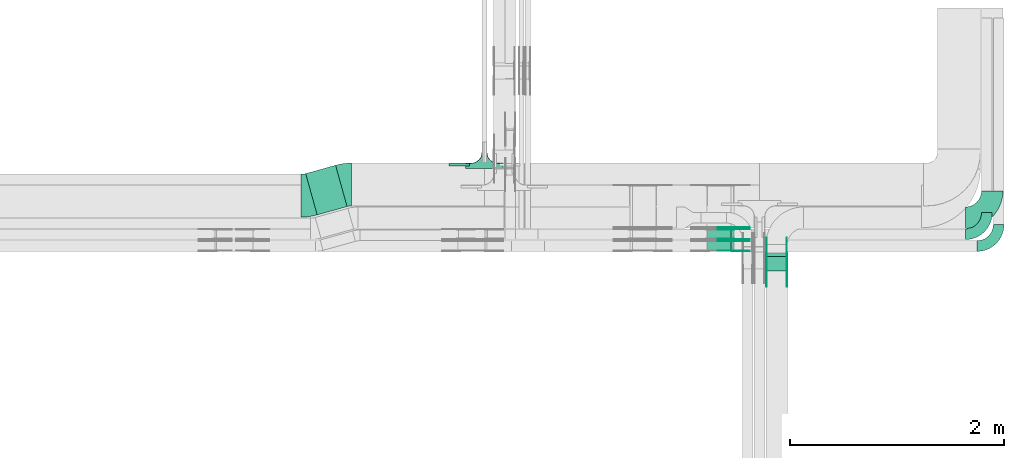
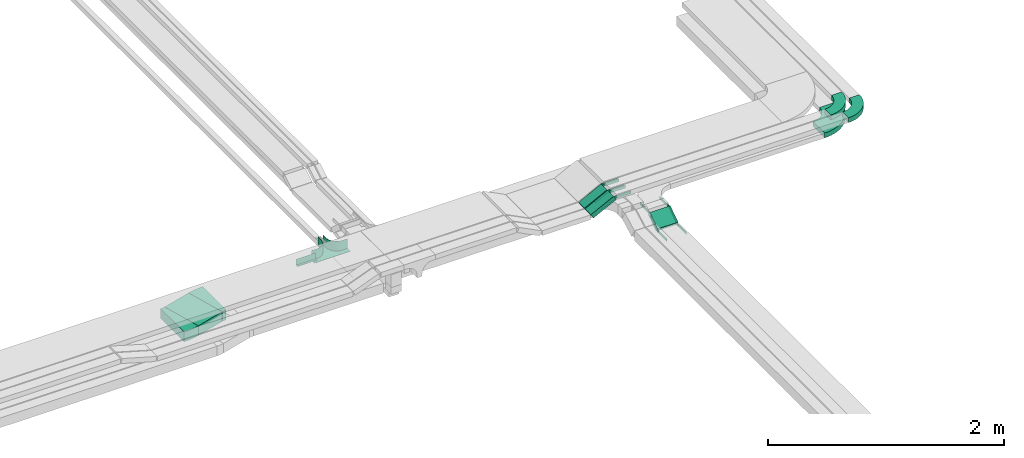
# One storey, part 23 of 28: 25 flow fittings, 4 flow segments.
"""IFC2X3 building model written with IfcOpenShell, lengths in millimetres."""

from ifc_helpers import new_model, entity, si_unit, converted_unit, derived_unit, direction, frame, frame_2d, origin, origin_2d_with_axis, place, context, subcontext, project, spatial, polyline, circle_curve, parameter, trimmed, segment, composite_curve, rectangle, outline, extrude, faceted_brep, source, transform, mapped, material, type_object, type_shapes, element, save


model = new_model("IFC2X3")

# Units and contexts
model_context = context("Model", 3, precision=0.01, world=origin(), true_north=direction((6.12303176911189e-17, 1.0)))
body_context = subcontext(model_context, "Body", "Model", "MODEL_VIEW")
ifc_project = project(units=[si_unit("LENGTHUNIT", "METRE", prefix="MILLI"), si_unit("AREAUNIT", "SQUARE_METRE"), si_unit("VOLUMEUNIT", "CUBIC_METRE"), converted_unit("PLANEANGLEUNIT", "DEGREE", entity("IfcRatioMeasure", 0.0174532925199433), si_unit("PLANEANGLEUNIT", "RADIAN"), dimensions=[0, 0, 0, 0, 0, 0, 0]), si_unit("MASSUNIT", "GRAM", prefix="KILO"), derived_unit("MASSDENSITYUNIT", [(si_unit("MASSUNIT", "GRAM", prefix="KILO"), 1), (si_unit("LENGTHUNIT", "METRE"), -3)]), derived_unit("MOMENTOFINERTIAUNIT", [(si_unit("LENGTHUNIT", "METRE"), 4)]), si_unit("TIMEUNIT", "SECOND"), si_unit("FREQUENCYUNIT", "HERTZ"), si_unit("THERMODYNAMICTEMPERATUREUNIT", "DEGREE_CELSIUS"), derived_unit("THERMALTRANSMITTANCEUNIT", [(si_unit("MASSUNIT", "GRAM", prefix="KILO"), 1), (si_unit("THERMODYNAMICTEMPERATUREUNIT", "KELVIN"), -1), (si_unit("TIMEUNIT", "SECOND"), -3)]), derived_unit("VOLUMETRICFLOWRATEUNIT", [(si_unit("LENGTHUNIT", "METRE"), 3), (si_unit("TIMEUNIT", "SECOND"), -1)]), derived_unit("MASSFLOWRATEUNIT", [(si_unit("MASSUNIT", "GRAM", prefix="KILO"), 1), (si_unit("TIMEUNIT", "SECOND"), -1)]), derived_unit("ROTATIONALFREQUENCYUNIT", [(si_unit("TIMEUNIT", "SECOND"), -1)]), si_unit("ELECTRICCURRENTUNIT", "AMPERE"), si_unit("ELECTRICVOLTAGEUNIT", "VOLT"), si_unit("POWERUNIT", "WATT"), si_unit("FORCEUNIT", "NEWTON", prefix="KILO"), si_unit("ILLUMINANCEUNIT", "LUX"), si_unit("LUMINOUSFLUXUNIT", "LUMEN"), si_unit("LUMINOUSINTENSITYUNIT", "CANDELA"), derived_unit("USERDEFINED", [(si_unit("MASSUNIT", "GRAM", prefix="KILO"), -1), (si_unit("LENGTHUNIT", "METRE"), -2), (si_unit("TIMEUNIT", "SECOND"), 3), (si_unit("LUMINOUSFLUXUNIT", "LUMEN"), 1)]), derived_unit("LINEARVELOCITYUNIT", [(si_unit("LENGTHUNIT", "METRE"), 1), (si_unit("TIMEUNIT", "SECOND"), -1)]), si_unit("PRESSUREUNIT", "PASCAL"), derived_unit("USERDEFINED", [(si_unit("LENGTHUNIT", "METRE"), -2), (si_unit("MASSUNIT", "GRAM", prefix="KILO"), 1), (si_unit("TIMEUNIT", "SECOND"), -2)]), derived_unit("LINEARFORCEUNIT", [(si_unit("MASSUNIT", "GRAM", prefix="KILO"), 1), (si_unit("LENGTHUNIT", "METRE"), 1), (si_unit("TIMEUNIT", "SECOND"), -2), (si_unit("LENGTHUNIT", "METRE"), -1)]), derived_unit("PLANARFORCEUNIT", [(si_unit("MASSUNIT", "GRAM", prefix="KILO"), 1), (si_unit("LENGTHUNIT", "METRE"), 1), (si_unit("TIMEUNIT", "SECOND"), -2), (si_unit("LENGTHUNIT", "METRE"), -2)])], contexts=[model_context])

# Site, building, storey
site_placement = place(None, frame((0.0, -0.00077364408347762, 0.0)))
site = spatial("IfcSite", under=ifc_project, at=site_placement, CompositionType="ELEMENT")
building_placement = place(site_placement, origin())
building = spatial("IfcBuilding", under=site, at=building_placement, CompositionType="ELEMENT")
storey_placement = place(building_placement, origin())
storey = spatial("IfcBuildingStorey", under=building, at=storey_placement, CompositionType="ELEMENT", Elevation=0.0)

# Flow segments
cable_carrier_segment_type = type_object("IfcCableCarrierSegmentType", PredefinedType="CABLETRAYSEGMENT")
flow_segment_1_placement = place(storey_placement, frame((62148.3888662909, 8640.69080652689, 2600.0)))
element("IfcFlowSegment", 1, at=flow_segment_1_placement, inside=storey, type_object=cable_carrier_segment_type, context=body_context, shape_type="SweptSolid", body=[
    extrude(rectangle(XDim=289.546419624688, YDim=399.999999999996, at=origin_2d_with_axis()), frame((193.213272355513, 231.55886420976, 0.0), z_axis=(0.0, 0.0, 1.0), x_axis=(0.963181508900078, 0.26885196840077, 0.0)), (0.0, 0.0, 1.0), 100.0),
])
flow_segment_2_placement = place(storey_placement, frame((66444.9973266601, 8118.92537783529, 2509.65637978712)))
element("IfcFlowSegment", 2, at=flow_segment_2_placement, inside=storey, type_object=cable_carrier_segment_type, context=body_context, shape_type="SweptSolid", body=[
    extrude(rectangle(XDim=49.9999999999992, YDim=160.399490584972, at=frame_2d((-1.49213974509621e-13, -2.29150032282632e-13), x_axis=(0.0, 1.0))), frame((0.0, 80.5727769550106, 65.3436202128766), z_axis=(1.0, 0.0, 0.0), x_axis=(0.0, -0.831466573945081, -0.555574780215976)), (0.0, 0.0, 1.0), 200.000000000007),
])
flow_segment_3_placement = place(storey_placement, frame((65897.5253950427, 8300.00006103515, 2736.3396381935)))
element("IfcFlowSegment", 3, at=flow_segment_3_placement, inside=storey, type_object=cable_carrier_segment_type, context=body_context, shape_type="SweptSolid", body=[
    extrude(rectangle(XDim=49.9999999999994, YDim=99.9999999999989, at=frame_2d((0.0, 0.0), x_axis=(0.0, 1.0))), frame((11.3497624934982, 50.0, 22.2751631047073), z_axis=(0.89100652418826, 0.0, 0.453990499739758), x_axis=(0.0, 1.0, 0.0)), (0.0, 0.0, 1.0), 248.398143723743),
])
flow_segment_4_placement = place(storey_placement, frame((65897.5253950427, 8410.0000610352, 2736.33963819349)))
element("IfcFlowSegment", 4, at=flow_segment_4_placement, inside=storey, type_object=cable_carrier_segment_type, context=body_context, shape_type="SweptSolid", body=[
    extrude(rectangle(XDim=50.0000000000027, YDim=100.000000000001, at=frame_2d((1.08357767203415e-12, 0.0), x_axis=(0.0, 1.0))), frame((11.3497624934808, 50.0, 22.2751631047117), z_axis=(0.891006524188364, 0.0, 0.453990499739555), x_axis=(0.0, 1.0, 0.0)), (0.0, 0.0, 1.0), 248.39814372396),
])

# Flow fittings
ifc_material_1 = material(Name="G")
cable_carrier_fitting_type_1 = type_object("IfcCableCarrierFittingType", PredefinedType="NOTDEFINED", material=ifc_material_1)
shared_shape_1 = source(origin(), body_context, "Body", "SweptSolid", [
    extrude(outline(composite_curve([segment(trimmed(circle_curve(frame_2d((-44.5901162790698, 0.0), x_axis=(1.0, 0.0)), 12.5), [parameter(90.0000000000007)], [parameter(270.0)], True, "PARAMETER"), True, "CONTINUOUS"), segment(polyline([(-44.5901162790697, -12.5), (-33.0901162790698, -12.5)]), True, "CONTINUOUS"), segment(polyline([(-33.0901162790698, -12.5), (-31.2296511627907, -14.5)]), True, "CONTINUOUS"), segment(polyline([(-31.2296511627907, -14.5), (108.90988372093, -14.5)]), True, "CONTINUOUS"), segment(polyline([(108.90988372093, -14.5), (108.90988372093, 14.5)]), True, "CONTINUOUS"), segment(polyline([(108.90988372093, 14.5), (-31.2296511627907, 14.5)]), True, "CONTINUOUS"), segment(polyline([(-31.2296511627907, 14.5), (-33.0901162790698, 12.5)]), True, "CONTINUOUS"), segment(polyline([(-33.0901162790698, 12.5), (-44.5901162790699, 12.5)]), True, "CONTINUOUS")], self_intersect=False)), frame((44.5901162790698, 0.0, 0.0), z_axis=(0.0, 0.0, -1.0), x_axis=(1.0, 0.0, 0.0)), (0.0, 0.0, -1.0), 2.0),
])
type_shapes(cable_carrier_fitting_type_1, [shared_shape_1])
for number, where, z_axis, x_axis in (
    (5, (66640.4573266703, 8274.32755701972, 2625.0), (1.0, 0.0, 0.0), (0.0, -0.831466573945132, -0.555574780215899)),
    (6, (66449.53732665, 8124.66875256084, 2525.0), (-1.0, 0.0, 0.0), (0.0, -1.0, 0.0)),
    (7, (66137.2939711935, 8395.46006104531, 2875.0), (0.0, 1.0, 0.0), (1.0, 0.0, 0.0)),
    (8, (66137.2939711938, 8505.46006104536, 2875.0), (0.0, 1.0, 0.0), (1.0, 0.0, 0.0)),
):
    element("IfcFlowFitting", number, at=place(storey_placement, frame(where, z_axis=z_axis, x_axis=x_axis)), inside=storey, type_object=cable_carrier_fitting_type_1, material=ifc_material_1, context=body_context, shape_type="MappedRepresentation", body=[
        mapped(shared_shape_1, transform((0.0, 0.0, 0.0), scale=1.0)),
    ])
cable_carrier_fitting_type_2 = type_object("IfcCableCarrierFittingType", PredefinedType="NOTDEFINED", material=ifc_material_1)
shared_shape_2 = source(origin(), body_context, "Body", "SweptSolid", [
    extrude(outline(composite_curve([segment(trimmed(circle_curve(frame_2d((-44.5901162790697, 0.0), x_axis=(1.0, 0.0)), 12.5), [parameter(90.0000000000007)], [parameter(270.0)], True, "PARAMETER"), True, "CONTINUOUS"), segment(polyline([(-44.5901162790697, -12.5), (-33.0901162790697, -12.5)]), True, "CONTINUOUS"), segment(polyline([(-33.0901162790697, -12.5), (-31.2296511627907, -14.5)]), True, "CONTINUOUS"), segment(polyline([(-31.2296511627907, -14.5), (108.90988372093, -14.5)]), True, "CONTINUOUS"), segment(polyline([(108.90988372093, -14.5), (108.90988372093, 14.5)]), True, "CONTINUOUS"), segment(polyline([(108.90988372093, 14.5), (-31.2296511627907, 14.5)]), True, "CONTINUOUS"), segment(polyline([(-31.2296511627907, 14.5), (-33.0901162790698, 12.5)]), True, "CONTINUOUS"), segment(polyline([(-33.0901162790698, 12.5), (-44.5901162790699, 12.5)]), True, "CONTINUOUS")], self_intersect=False)), frame((44.5901162790697, 0.0, 0.0)), (0.0, 0.0, 1.0), 2.0),
])
type_shapes(cable_carrier_fitting_type_2, [shared_shape_2])
for number, where, z_axis, x_axis in (
    (9, (66449.53732665, 8274.32755701972, 2625.0), (-1.0, 0.0, 0.0), (0.0, -0.831466573945132, -0.555574780215899)),
    (10, (66640.4573266703, 8124.66875256084, 2525.0), (1.0, 0.0, 0.0), (0.0, -1.0, 0.0)),
    (11, (66137.2939711935, 8304.54006102499, 2875.0), (0.0, -1.0, 0.0), (1.0, 0.0, 0.0)),
    (12, (66137.2939711938, 8524.54006102498, 2875.0), (0.0, -1.0, 0.0), (1.0, 0.0, 0.0)),
    (13, (66137.2939711938, 8414.54006102504, 2875.0), (0.0, -1.0, 0.0), (1.0, 0.0, 0.0)),
):
    element("IfcFlowFitting", number, at=place(storey_placement, frame(where, z_axis=z_axis, x_axis=x_axis)), inside=storey, type_object=cable_carrier_fitting_type_2, material=ifc_material_1, context=body_context, shape_type="MappedRepresentation", body=[
        mapped(shared_shape_2, transform((0.0, 0.0, 0.0), scale=1.0)),
    ])
cable_carrier_fitting_type_3 = type_object("IfcCableCarrierFittingType", PredefinedType="NOTDEFINED", material=ifc_material_1)
shared_shape_3 = source(origin(), body_context, "Body", "SweptSolid", [
    extrude(outline(composite_curve([segment(trimmed(circle_curve(frame_2d((-44.5901162790698, 0.0), x_axis=(1.0, 0.0)), 12.5), [parameter(90.0000000000007)], [parameter(270.0)], True, "PARAMETER"), True, "CONTINUOUS"), segment(polyline([(-44.5901162790697, -12.5), (-33.0901162790698, -12.5)]), True, "CONTINUOUS"), segment(polyline([(-33.0901162790698, -12.5), (-31.2296511627907, -14.5)]), True, "CONTINUOUS"), segment(polyline([(-31.2296511627907, -14.5), (108.90988372093, -14.5)]), True, "CONTINUOUS"), segment(polyline([(108.90988372093, -14.5), (108.90988372093, 14.5)]), True, "CONTINUOUS"), segment(polyline([(108.90988372093, 14.5), (-31.2296511627907, 14.5)]), True, "CONTINUOUS"), segment(polyline([(-31.2296511627907, 14.5), (-33.0901162790698, 12.5)]), True, "CONTINUOUS"), segment(polyline([(-33.0901162790698, 12.5), (-44.5901162790699, 12.5)]), True, "CONTINUOUS")], self_intersect=False)), frame((44.5901162790698, 0.0, 0.0), z_axis=(0.0, 0.0, -1.0), x_axis=(1.0, 0.0, 0.0)), (0.0, 0.0, -1.0), 2.0),
])
type_shapes(cable_carrier_fitting_type_3, [shared_shape_3])
for number, where, z_axis, x_axis in (
    (14, (66451.53732665, 8274.32755701971, 2625.0), (-1.0, 0.0, 0.0), (0.0, 1.0, 0.0)),
    (15, (66638.4573266703, 8124.66875256083, 2525.0), (1.0, 0.0, 0.0), (0.0, 0.831466573945084, 0.555574780215971)),
    (16, (66137.2939711935, 8306.54006102499, 2875.0), (0.0, -1.0, 0.0), (-0.891006524188267, 0.0, -0.453990499739745)),
    (17, (66137.2939711938, 8526.54006102499, 2875.0), (0.0, -1.0, 0.0), (-0.891006524188393, 0.0, -0.453990499739498)),
    (18, (66137.2939711938, 8416.54006102504, 2875.0), (0.0, -1.0, 0.0), (-0.891006524188395, 0.0, -0.453990499739495)),
):
    element("IfcFlowFitting", number, at=place(storey_placement, frame(where, z_axis=z_axis, x_axis=x_axis)), inside=storey, type_object=cable_carrier_fitting_type_3, material=ifc_material_1, context=body_context, shape_type="MappedRepresentation", body=[
        mapped(shared_shape_3, transform((0.0, 0.0, 0.0), scale=1.0)),
    ])
cable_carrier_fitting_type_4 = type_object("IfcCableCarrierFittingType", PredefinedType="NOTDEFINED", material=ifc_material_1)
shared_shape_4 = source(origin(), body_context, "Body", "SweptSolid", [
    extrude(outline(composite_curve([segment(trimmed(circle_curve(frame_2d((-44.5901162790697, 0.0), x_axis=(1.0, 0.0)), 12.5), [parameter(90.0000000000007)], [parameter(270.0)], True, "PARAMETER"), True, "CONTINUOUS"), segment(polyline([(-44.5901162790697, -12.5), (-33.0901162790697, -12.5)]), True, "CONTINUOUS"), segment(polyline([(-33.0901162790697, -12.5), (-31.2296511627907, -14.5)]), True, "CONTINUOUS"), segment(polyline([(-31.2296511627907, -14.5), (108.90988372093, -14.5)]), True, "CONTINUOUS"), segment(polyline([(108.90988372093, -14.5), (108.90988372093, 14.5)]), True, "CONTINUOUS"), segment(polyline([(108.90988372093, 14.5), (-31.2296511627907, 14.5)]), True, "CONTINUOUS"), segment(polyline([(-31.2296511627907, 14.5), (-33.0901162790698, 12.5)]), True, "CONTINUOUS"), segment(polyline([(-33.0901162790698, 12.5), (-44.5901162790699, 12.5)]), True, "CONTINUOUS")], self_intersect=False)), frame((44.5901162790697, 0.0, 0.0)), (0.0, 0.0, 1.0), 2.0),
])
type_shapes(cable_carrier_fitting_type_4, [shared_shape_4])
for number, where, z_axis, x_axis in (
    (19, (66638.4573266703, 8274.32755701971, 2625.0), (1.0, 0.0, 0.0), (0.0, 1.0, 0.0)),
    (20, (66451.53732665, 8124.66875256083, 2525.0), (-1.0, 0.0, 0.0), (0.0, 0.831466573945084, 0.555574780215971)),
    (21, (66137.2939711935, 8393.46006104531, 2875.0), (0.0, 1.0, 0.0), (-0.891006524188267, 0.0, -0.453990499739745)),
    (22, (66137.2939711938, 8503.46006104536, 2875.0), (0.0, 1.0, 0.0), (-0.891006524188395, 0.0, -0.453990499739495)),
):
    element("IfcFlowFitting", number, at=place(storey_placement, frame(where, z_axis=z_axis, x_axis=x_axis)), inside=storey, type_object=cable_carrier_fitting_type_4, material=ifc_material_1, context=body_context, shape_type="MappedRepresentation", body=[
        mapped(shared_shape_4, transform((0.0, 0.0, 0.0), scale=1.0)),
    ])
ifc_material_2 = material()
cable_carrier_fitting_type_5 = type_object("IfcCableCarrierFittingType", Name="470_DKC_S5_Variable Angle Elbow 0-45:-", PredefinedType="NOTDEFINED", material=ifc_material_2)
shared_shape_5 = source(origin(), body_context, "Body", "SweptSolid", [
    extrude(outline(composite_curve([segment(polyline([(-48.0398898473619, -206.510448934587), (-47.0398898473601, -206.510448934587)]), True, "CONTINUOUS"), segment(trimmed(circle_curve(frame_2d((-47.039889847361, 343.489551065413), x_axis=(0.0, -1.0)), 550.0), [parameter(0.0)], [parameter(15.5959637059979)], True, "PARAMETER"), True, "CONTINUOUS"), segment(polyline([(100.828692773066, -186.260278829629), (101.791874281966, -185.991426861228)]), True, "CONTINUOUS"), segment(polyline([(101.791874281965, -185.991426861228), (-5.74891307834419, 199.281176698803)]), True, "CONTINUOUS"), segment(polyline([(-5.7489130783442, 199.281176698803), (-6.71209458724463, 199.012324730402)]), True, "CONTINUOUS"), segment(trimmed(circle_curve(frame_2d((-47.039889847361, 343.489551065413), x_axis=(0.0, -1.0)), 150.0), [parameter(0.0)], [parameter(15.5959637059979)], True, "PARAMETER"), False, "CONTINUOUS"), segment(polyline([(-47.0398898473601, 193.489551065413), (-48.0398898473619, 193.489551065413)]), True, "CONTINUOUS"), segment(polyline([(-48.0398898473619, 193.489551065413), (-48.0398898473619, -206.510448934587)]), True, "CONTINUOUS")], self_intersect=False)), frame((-0.89158694867555, 6.51044893457875, -50.0)), (0.0, 0.0, 1.0), 99.999999999999),
])
type_shapes(cable_carrier_fitting_type_5, [shared_shape_5])
flow_fitting_1_placement = place(storey_placement, frame((62528.174910975, 8924.32755701976, 2650.0), z_axis=(0.0, 0.0, 1.0), x_axis=(-1.0, 0.0, 0.0)))
element("IfcFlowFitting", 23, at=flow_fitting_1_placement, inside=storey, type_object=cable_carrier_fitting_type_5, material=ifc_material_2, Name="470_DKC_S5_Variable Angle Elbow 0-45:-", ObjectType="470_DKC_S5_Variable Angle Elbow 0-45:-", context=body_context, shape_type="MappedRepresentation", body=[
    mapped(shared_shape_5, transform((0.0, 0.0, 0.0), scale=1.0)),
])
flow_fitting_2_placement = place(storey_placement, frame((62155.0293663179, 8820.17178445355, 2650.0)))
element("IfcFlowFitting", 24, at=flow_fitting_2_placement, inside=storey, type_object=cable_carrier_fitting_type_5, material=ifc_material_2, Name="470_DKC_S5_Variable Angle Elbow 0-45:-", ObjectType="470_DKC_S5_Variable Angle Elbow 0-45:-", context=body_context, shape_type="MappedRepresentation", body=[
    mapped(shared_shape_5, transform((0.0, 0.0, 0.0), scale=1.0)),
])
ifc_material_3 = material()
cable_carrier_fitting_type_6 = type_object("IfcCableCarrierFittingType", PredefinedType="NOTDEFINED", material=ifc_material_3)
shared_shape_6 = source(origin(), body_context, "Body", "Brep", [
    faceted_brep([(1.0, 197.500000000001, 50.0), (1.0, 197.500000000001, -47.5000000000011), (1.0, -200.0, -47.5000000000011), (1.0, -200.0, -50.0), (1.0, 200.0, -50.0), (1.0, 200.0, 50.0), (-1.0, 197.500000000001, 50.0), (-1.0, 200.0, 50.0), (-1.0, 200.0, -50.0), (-1.0, -200.0, -50.0), (-1.0, -200.0, -47.5000000000011), (-1.0, 197.500000000001, -47.5000000000011)], [[[0, 1, 2, 3, 4, 5]], [[6, 7, 8, 9, 10, 11]], [[1, 0, 6, 11]], [[2, 1, 11, 10]], [[3, 2, 10, 9]], [[4, 3, 9, 8]], [[5, 4, 8, 7]], [[0, 5, 7, 6]]]),
    faceted_brep([(22.4999999999995, -300.0, 50.0), (22.4999999999995, -350.0, 50.0), (25.0, -350.0, 50.0), (25.0, -300.0, 50.0), (28.4074173710929, -274.118095489749, 50.0), (38.3974596215557, -250.0, 50.0), (54.2893218813448, -229.289321881346, 50.0), (75.0, -213.397459621557, 50.0), (99.1180954897473, -203.407417371094, 50.0), (125.0, -200.0, 50.0), (175.0, -200.0, 50.0), (175.0, -197.5, 50.0), (125.0, -197.500000000001, 50.0), (98.4710478769916, -200.992602805371, 50.0), (73.75, -211.232396112095, 50.0), (52.5215549283788, -227.521554928379, 50.0), (36.2323961120948, -248.75, 50.0), (25.9926028053702, -273.471047876992, 50.0), (-99.1180954897534, -203.407417371094, 50.0), (-75.0, -213.397459621557, 50.0), (-54.2893218813509, -229.289321881346, 50.0), (-38.3974596215619, -250.0, 50.0), (-28.407417371099, -274.118095489749, 50.0), (-25.0, -300.0, 50.0), (-25.0, -350.0, 50.0), (-22.5000000000058, -350.0, 50.0), (-22.5000000000058, -300.0, 50.0), (-25.9926028053763, -273.471047876992, 50.0), (-36.2323961121008, -248.750000000001, 50.0), (-52.5215549283845, -227.52155492838, 50.0), (-73.7500000000056, -211.232396112096, 50.0), (-98.4710478769971, -200.992602805371, 50.0), (-125.0, -197.500000000001, 50.0), (-175.0, -197.500000000001, 50.0), (-175.0, -200.0, 50.0), (-125.0, -200.0, 50.0), (-99.118095489754, -203.407417371094, -50.0), (-114.212641733723, -201.420182658132, -50.0), (-125.0, -200.0, -50.0), (-125.0, -200.0, -52.5), (-112.05904774488, -201.703708685552, -52.5000000000001), (-99.118095489753, -203.407417371099, -52.5000000000001), (-75.0, -213.397459621557, -50.0), (-87.0590477448822, -208.402438496329, -50.0), (-87.0590477448797, -208.40243849633, -52.5000000000001), (-75.0, -213.397459621562, -52.5000000000001), (-64.6446609406813, -221.343390751454, -50.0), (-54.2893218813514, -229.289321881346, -50.0), (-64.6446609406784, -221.343390751456, -52.5000000000001), (-54.2893218813506, -229.289321881351, -52.5000000000001), (-28.4074173710992, -274.118095489748, -50.0), (-33.4024384963323, -262.059047744874, -50.0), (-38.3974596215622, -250.0, -50.0), (-38.3974596215616, -250.0, -52.5000000000001), (-33.4024384963304, -262.059047744879, -52.5000000000001), (-28.4074173710987, -274.118095489753, -52.5000000000001), (-25.0, -300.0, -50.0), (-26.7037086855529, -287.059047744874, -50.0), (-26.420182658065, -289.21264173423, -52.5000000000001), (-25.0, -300.0, -52.5), (-46.3433907514592, -239.644660940674, -50.0), (-46.3433907514565, -239.644660940678, -52.5000000000001), (-25.0, -350.0, -52.5), (25.0, -350.0, -52.5), (22.4999999999995, -350.0, -50.0), (-22.5000000000058, -350.0, -50.0), (-22.5000000000058, -300.0, -50.0), (-25.9926028053761, -273.471047876993, -50.0), (-36.2323961121004, -248.750000000002, -50.0), (-52.5215549283841, -227.52155492838, -50.0), (-73.750000000005, -211.232396112096, -50.0), (-98.4710478769965, -200.992602805371, -50.0), (-125.0, -197.500000000001, -50.0), (25.0, -300.0, -52.5), (25.0, -300.0, -50.0), (28.4074173710927, -274.11809548975, -50.0), (33.4024384963257, -262.059047744877, -50.0), (38.3974596215554, -250.0, -50.0), (28.4074173710929, -274.118095489754, -52.5000000000001), (33.402438496324, -262.059047744881, -52.5000000000001), (38.3974596215557, -250.0, -52.5000000000001), (46.343390751452, -239.644660940677, -50.0), (54.2893218813443, -229.289321881347, -50.0), (46.3433907514499, -239.644660940679, -52.5000000000001), (54.2893218813448, -229.289321881352, -52.5000000000001), (26.4201826582159, -289.212641733042, -50.0), (26.7037086855462, -287.059047744881, -52.5), (75.0, -213.397459621557, -50.0), (87.0590477448741, -208.40243849633, -50.0), (99.1180954897468, -203.407417371094, -50.0), (75.0, -213.397459621562, -52.5000000000001), (87.059047744873, -208.402438496331, -52.5000000000001), (99.1180954897475, -203.407417371099, -52.5000000000001), (112.059047744873, -201.703708685553, -50.0), (125.0, -200.0, -50.0), (114.212641734219, -201.420182658066, -52.5000000000001), (125.0, -200.0, -52.5), (64.6446609406736, -221.343390751456, -50.0), (64.6446609406717, -221.343390751457, -52.5000000000001), (98.471047876991, -200.992602805371, -50.0), (73.7499999999994, -211.232396112096, -50.0), (52.5215549283783, -227.52155492838, -50.0), (125.0, -197.500000000001, -50.0), (36.2323961120945, -248.750000000001, -50.0), (25.99260280537, -273.471047876993, -50.0), (22.4999999999997, -300.0, -50.0), (-175.0, -197.500000000001, -50.0), (175.0, -197.5, -50.0), (-175.0, -150.0, -50.0), (-175.0, -150.0, -52.5), (-175.0, -200.0, -52.5), (175.0, -200.0, -52.5), (175.0, -150.0, -52.5), (175.0, -150.0, -50.0)], [[[0, 1, 2, 3, 4, 5, 6, 7, 8, 9, 10, 11, 12, 13, 14, 15, 16, 17]], [[18, 19, 20, 21, 22, 23, 24, 25, 26, 27, 28, 29, 30, 31, 32, 33, 34, 35]], [[18, 35, 36]], [[35, 37, 36]], [[35, 38, 37]], [[37, 38, 39]], [[37, 39, 40]], [[36, 40, 41]], [[37, 40, 36]], [[19, 18, 42]], [[18, 43, 42]], [[18, 36, 43]], [[36, 41, 43]], [[44, 43, 41]], [[43, 44, 42]], [[44, 45, 42]], [[19, 42, 46]], [[19, 46, 47]], [[47, 20, 19]], [[46, 42, 45]], [[46, 45, 48]], [[48, 49, 47]], [[46, 48, 47]], [[22, 21, 50]], [[21, 51, 50]], [[21, 52, 51]], [[52, 53, 51]], [[54, 51, 53]], [[51, 54, 50]], [[54, 55, 50]], [[23, 22, 56]], [[22, 57, 56]], [[22, 50, 57]], [[50, 55, 57]], [[58, 57, 55]], [[58, 59, 56]], [[57, 58, 56]], [[20, 47, 60]], [[20, 60, 52]], [[52, 21, 20]], [[60, 47, 49]], [[60, 49, 61]], [[60, 61, 52]], [[61, 53, 52]], [[24, 23, 56, 59, 62]], [[25, 24, 62, 63, 2, 1, 64, 65]], [[26, 25, 65, 66]], [[27, 67, 68, 28]], [[28, 68, 69, 29]], [[66, 67, 27, 26]], [[30, 70, 71, 31]], [[31, 71, 72, 32]], [[29, 69, 70, 30]], [[3, 2, 63, 73, 74]], [[5, 4, 75]], [[5, 75, 76]], [[5, 76, 77]], [[75, 78, 76]], [[79, 76, 78]], [[76, 79, 77]], [[79, 80, 77]], [[6, 5, 77]], [[6, 77, 81]], [[6, 81, 82]], [[81, 77, 80]], [[81, 80, 83]], [[83, 84, 82]], [[81, 83, 82]], [[74, 4, 3]], [[4, 74, 85]], [[85, 74, 73]], [[85, 73, 86]], [[85, 86, 75]], [[75, 86, 78]], [[4, 85, 75]], [[8, 7, 87]], [[8, 87, 88]], [[8, 88, 89]], [[87, 90, 88]], [[91, 88, 90]], [[88, 91, 89]], [[91, 92, 89]], [[9, 8, 89]], [[9, 89, 93]], [[9, 93, 94]], [[89, 92, 93]], [[95, 93, 92]], [[95, 96, 94]], [[93, 95, 94]], [[7, 82, 97]], [[6, 82, 7]], [[7, 97, 87]], [[97, 82, 84]], [[97, 84, 98]], [[97, 98, 87]], [[98, 90, 87]], [[13, 99, 100, 14]], [[14, 100, 101, 15]], [[102, 99, 13, 12]], [[16, 103, 104, 17]], [[17, 104, 105, 0]], [[15, 101, 103, 16]], [[1, 0, 105, 64]], [[33, 32, 72, 106]], [[12, 11, 107, 102]], [[34, 33, 106, 108, 109, 110]], [[35, 34, 110, 39, 38]], [[10, 9, 94, 96, 111]], [[10, 111, 112, 113, 107, 11]], [[107, 113, 108, 106, 72, 71, 70, 69, 68, 67, 66, 65, 64, 105, 104, 103, 101, 100, 99, 102]], [[110, 109, 112, 111, 96, 95, 92, 91, 90, 98, 84, 83, 80, 79, 78, 86, 73, 63, 62, 59, 58, 55, 54, 53, 61, 49, 48, 45, 44, 41, 40, 39]], [[108, 113, 112, 109]]]),
])
type_shapes(cable_carrier_fitting_type_6, [shared_shape_6])
flow_fitting_3_placement = place(storey_placement, frame((63817.1849606245, 8924.32755701977, 2650.0), z_axis=(0.0, 0.0, 1.0), x_axis=(-1.0, 0.0, 0.0)))
element("IfcFlowFitting", 25, at=flow_fitting_3_placement, inside=storey, type_object=cable_carrier_fitting_type_6, material=ifc_material_3, context=body_context, shape_type="MappedRepresentation", body=[
    mapped(shared_shape_6, transform((0.0, 0.0, 0.0), scale=1.0)),
])
cable_carrier_fitting_type_7 = type_object("IfcCableCarrierFittingType", PredefinedType="NOTDEFINED", material=ifc_material_3)
shared_shape_7 = source(origin(), body_context, "Body", "SweptSolid", [
    extrude(outline(polyline([(-21.5000000000001, -9.16666666666668), (40.5, -9.16666666666668), (40.5, -6.66666666666664), (-19.0, -6.66666666666664), (-19.0, 15.8333333333333), (-21.5000000000001, 15.8333333333333), (-21.5000000000001, -9.16666666666668)])), frame((-95.0, -9.16666666666668, -26.0), z_axis=(1.0, 0.0, 0.0), x_axis=(0.0, 0.0, 1.0)), (0.0, 0.0, 1.0), 190.0),
])
type_shapes(cable_carrier_fitting_type_7, [shared_shape_7])
flow_fitting_4_placement = place(storey_placement, frame((63582.1849606245, 9121.82755701977, 2650.0)))
element("IfcFlowFitting", 26, at=flow_fitting_4_placement, inside=storey, type_object=cable_carrier_fitting_type_7, material=ifc_material_3, context=body_context, shape_type="MappedRepresentation", body=[
    mapped(shared_shape_7, transform((0.0, 0.0, 0.0), scale=1.0)),
])
cable_carrier_fitting_type_8 = type_object("IfcCableCarrierFittingType", Name="470_DKC_S5_Variable Angle Elbow 0-45:-", PredefinedType="NOTDEFINED", material=ifc_material_2)
shared_shape_8 = source(origin(), body_context, "Body", "SweptSolid", [
    extrude(outline(composite_curve([segment(polyline([(-100.750000000001, -150.25), (-99.7499999999994, -150.25)]), True, "CONTINUOUS"), segment(trimmed(circle_curve(frame_2d((-99.7499999999997, 99.7499999999995), x_axis=(0.0, -1.0)), 250.0), [parameter(0.0)], [parameter(90.0000000000001)], True, "PARAMETER"), True, "CONTINUOUS"), segment(polyline([(150.25, 99.75), (150.25, 100.749999999999)]), True, "CONTINUOUS"), segment(polyline([(150.25, 100.749999999999), (50.25, 100.75)]), True, "CONTINUOUS"), segment(polyline([(50.25, 100.75), (50.25, 99.7499999999998)]), True, "CONTINUOUS"), segment(trimmed(circle_curve(frame_2d((-99.7499999999997, 99.7499999999995), x_axis=(0.0, -1.0)), 150.0), [parameter(0.0)], [parameter(90.0000000000001)], True, "PARAMETER"), False, "CONTINUOUS"), segment(polyline([(-99.7499999999994, -50.2500000000003), (-100.750000000001, -50.2500000000003)]), True, "CONTINUOUS"), segment(polyline([(-100.750000000001, -50.2500000000003), (-100.750000000001, -150.25)]), True, "CONTINUOUS")], self_intersect=False)), frame((-100.249999999991, 100.249999999992, -25.0)), (0.0, 0.0, 1.0), 49.9999999999997),
])
type_shapes(cable_carrier_fitting_type_8, [shared_shape_8])
for number, where, name in (
    (27, (68616.0094990459, 8350.00006103517, 2875.0), "470_DKC_S5_Variable Angle Elbow 0-45:-"),
    (28, (68506.0094990459, 8460.00006103522, 2875.0), "470_DKC_S5_Variable Angle Elbow 0-45:-"),
):
    element("IfcFlowFitting", number, at=place(storey_placement, frame(where)), inside=storey, type_object=cable_carrier_fitting_type_8, material=ifc_material_2, Name=name, ObjectType="470_DKC_S5_Variable Angle Elbow 0-45:-", context=body_context, shape_type="MappedRepresentation", body=[
        mapped(shared_shape_8, transform((0.0, 0.0, 0.0), scale=1.0)),
    ])
cable_carrier_fitting_type_9 = type_object("IfcCableCarrierFittingType", Name="470_DKC_S5_Variable Angle Elbow 0-45:-", PredefinedType="NOTDEFINED", material=ifc_material_2)
shared_shape_9 = source(origin(), body_context, "Body", "SweptSolid", [
    extrude(outline(composite_curve([segment(polyline([(-125.750000000004, -225.249999999998), (-124.750000000003, -225.249999999998)]), True, "CONTINUOUS"), segment(trimmed(circle_curve(frame_2d((-124.749999999998, 124.750000000002), x_axis=(0.0, -1.0)), 350.0), [parameter(0.0)], [parameter(90.0000000000001)], True, "PARAMETER"), True, "CONTINUOUS"), segment(polyline([(225.250000000002, 124.749999999996), (225.250000000002, 125.749999999995)]), True, "CONTINUOUS"), segment(polyline([(225.250000000002, 125.749999999995), (25.2500000000021, 125.750000000001)]), True, "CONTINUOUS"), segment(polyline([(25.2500000000021, 125.750000000001), (25.2500000000021, 124.749999999999)]), True, "CONTINUOUS"), segment(trimmed(circle_curve(frame_2d((-124.749999999998, 124.750000000002), x_axis=(0.0, -1.0)), 150.0), [parameter(0.0)], [parameter(90.0000000000001)], True, "PARAMETER"), False, "CONTINUOUS"), segment(polyline([(-124.75, -25.2499999999982), (-125.750000000001, -25.2499999999981)]), True, "CONTINUOUS"), segment(polyline([(-125.750000000001, -25.2499999999981), (-125.750000000004, -225.249999999998)]), True, "CONTINUOUS")], self_intersect=False)), frame((-125.249999999991, 125.249999999992, -25.0)), (0.0, 0.0, 1.0), 50.000000000001),
])
type_shapes(cable_carrier_fitting_type_9, [shared_shape_9])
flow_fitting_5_placement = place(storey_placement, frame((68556.0094990459, 8614.32755701971, 2625.0)))
element("IfcFlowFitting", 29, at=flow_fitting_5_placement, inside=storey, type_object=cable_carrier_fitting_type_9, material=ifc_material_2, Name="470_DKC_S5_Variable Angle Elbow 0-45:-", ObjectType="470_DKC_S5_Variable Angle Elbow 0-45:-", context=body_context, shape_type="MappedRepresentation", body=[
    mapped(shared_shape_9, transform((0.0, 0.0, 0.0), scale=1.0)),
])

save(model, "model.ifc")
